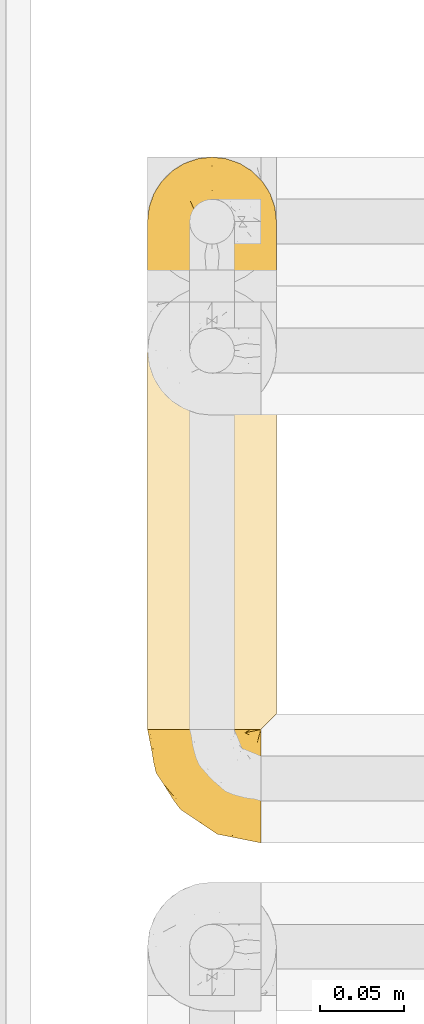
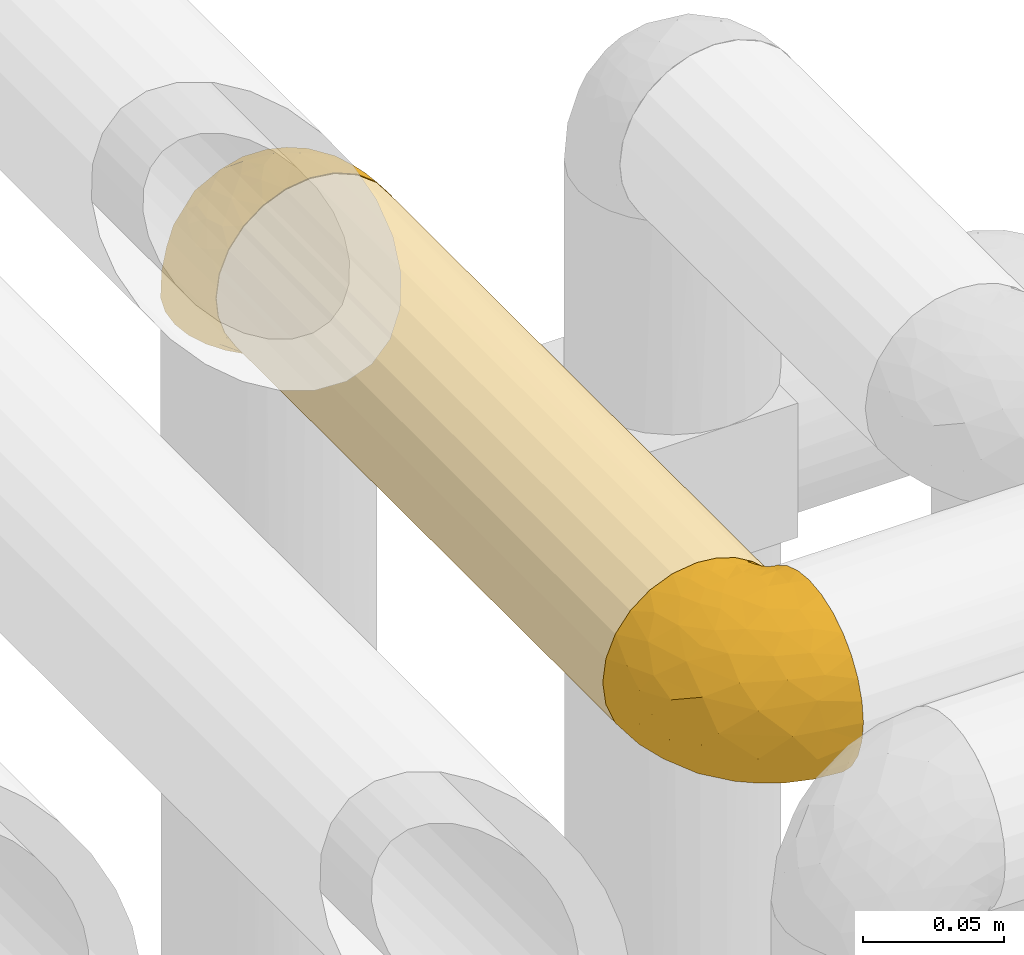
# One storey, part 286 of 827: 3 coverings.
"""IFC2X3 building model written with IfcOpenShell, lengths in millimetres."""

from ifc_helpers import new_model, entity, si_unit, converted_unit, derived_unit, direction, frame, origin, place, context, subcontext, project, spatial, faceted_brep, element, save


model = new_model("IFC2X3")

# Units and contexts
model_context = context("Model", 3, precision=0.01, world=origin(), true_north=direction((6.12303176911189e-17, 1.0)))
body_context = subcontext(model_context, "Body", "Model", "MODEL_VIEW")
ifc_project = project(units=[si_unit("LENGTHUNIT", "METRE", prefix="MILLI"), si_unit("AREAUNIT", "SQUARE_METRE"), si_unit("VOLUMEUNIT", "CUBIC_METRE"), converted_unit("PLANEANGLEUNIT", "DEGREE", entity("IfcRatioMeasure", 0.0174532925199433), si_unit("PLANEANGLEUNIT", "RADIAN"), dimensions=[0, 0, 0, 0, 0, 0, 0]), si_unit("MASSUNIT", "GRAM", prefix="KILO"), derived_unit("MASSDENSITYUNIT", [(si_unit("MASSUNIT", "GRAM", prefix="KILO"), 1), (si_unit("LENGTHUNIT", "METRE"), -3)]), derived_unit("MOMENTOFINERTIAUNIT", [(si_unit("LENGTHUNIT", "METRE"), 4)]), si_unit("TIMEUNIT", "SECOND"), si_unit("FREQUENCYUNIT", "HERTZ"), si_unit("THERMODYNAMICTEMPERATUREUNIT", "DEGREE_CELSIUS"), derived_unit("THERMALTRANSMITTANCEUNIT", [(si_unit("MASSUNIT", "GRAM", prefix="KILO"), 1), (si_unit("THERMODYNAMICTEMPERATUREUNIT", "KELVIN"), -1), (si_unit("TIMEUNIT", "SECOND"), -3)]), derived_unit("VOLUMETRICFLOWRATEUNIT", [(si_unit("LENGTHUNIT", "METRE"), 3), (si_unit("TIMEUNIT", "SECOND"), -1)]), derived_unit("MASSFLOWRATEUNIT", [(si_unit("MASSUNIT", "GRAM", prefix="KILO"), 1), (si_unit("TIMEUNIT", "SECOND"), -1)]), derived_unit("ROTATIONALFREQUENCYUNIT", [(si_unit("TIMEUNIT", "SECOND"), -1)]), si_unit("ELECTRICCURRENTUNIT", "AMPERE"), si_unit("ELECTRICVOLTAGEUNIT", "VOLT"), si_unit("POWERUNIT", "WATT"), si_unit("FORCEUNIT", "NEWTON", prefix="KILO"), si_unit("ILLUMINANCEUNIT", "LUX"), si_unit("LUMINOUSFLUXUNIT", "LUMEN"), si_unit("LUMINOUSINTENSITYUNIT", "CANDELA"), derived_unit("USERDEFINED", [(si_unit("MASSUNIT", "GRAM", prefix="KILO"), -1), (si_unit("LENGTHUNIT", "METRE"), -2), (si_unit("TIMEUNIT", "SECOND"), 3), (si_unit("LUMINOUSFLUXUNIT", "LUMEN"), 1)]), derived_unit("LINEARVELOCITYUNIT", [(si_unit("LENGTHUNIT", "METRE"), 1), (si_unit("TIMEUNIT", "SECOND"), -1)]), si_unit("PRESSUREUNIT", "PASCAL"), derived_unit("USERDEFINED", [(si_unit("LENGTHUNIT", "METRE"), -2), (si_unit("MASSUNIT", "GRAM", prefix="KILO"), 1), (si_unit("TIMEUNIT", "SECOND"), -2)]), derived_unit("LINEARFORCEUNIT", [(si_unit("MASSUNIT", "GRAM", prefix="KILO"), 1), (si_unit("LENGTHUNIT", "METRE"), 1), (si_unit("TIMEUNIT", "SECOND"), -2), (si_unit("LENGTHUNIT", "METRE"), -1)]), derived_unit("PLANARFORCEUNIT", [(si_unit("MASSUNIT", "GRAM", prefix="KILO"), 1), (si_unit("LENGTHUNIT", "METRE"), 1), (si_unit("TIMEUNIT", "SECOND"), -2), (si_unit("LENGTHUNIT", "METRE"), -2)])], contexts=[model_context])

# Site, building, storey
site_placement = place(None, origin())
site = spatial("IfcSite", under=ifc_project, at=site_placement, CompositionType="ELEMENT")
building_placement = place(site_placement, origin())
building = spatial("IfcBuilding", under=site, at=building_placement, CompositionType="ELEMENT")
storey_placement = place(building_placement, frame((0.0, 0.0, 28200.0)))
storey = spatial("IfcBuildingStorey", under=building, at=storey_placement, Name="08", CompositionType="ELEMENT", Elevation=28200.0)

# Coverings
covering_1_placement = place(storey_placement, frame((34787.85, 15517.5, 2960.0)))
element("IfcCovering", 1, at=covering_1_placement, inside=storey, Name=":ADSK_", ObjectType=":ADSK_", PredefinedType="INSULATION", context=body_context, shape_type="Brep", body=[
    faceted_brep([(20.8, 1.6, 6.74), (30.06, 1.6, 2.9), (40.0, 1.6, 1.6), (48.2, 1.6, 2.48), (56.01, 1.6, 5.09), (63.08, 1.6, 9.31), (69.1, 1.6, 14.94), (69.1, 1.6, 65.05), (63.08, 1.6, 70.68), (56.01, 1.6, 74.9), (48.2, 1.6, 77.51), (40.0, 1.6, 78.4), (30.06, 1.6, 77.09), (20.8, 1.6, 73.25), (12.84, 1.6, 67.15), (6.74, 1.6, 59.2), (2.9, 1.6, 49.93), (1.6, 1.6, 40.0), (2.9, 1.6, 30.06), (6.74, 1.6, 20.8), (12.84, 1.6, 12.84), (14.94, 275.44, 10.9), (9.31, 275.44, 16.91), (5.09, 275.44, 23.98), (2.48, 275.44, 31.79), (1.6, 275.44, 40.0), (2.9, 275.44, 49.93), (6.74, 275.44, 59.2), (12.84, 275.44, 67.15), (20.8, 275.44, 73.25), (30.06, 275.44, 77.09), (40.0, 275.44, 78.4), (49.93, 275.44, 77.09), (59.2, 275.44, 73.25), (67.15, 275.44, 67.15), (73.25, 275.44, 59.2), (77.09, 275.44, 49.93), (78.4, 275.44, 40.0), (77.51, 275.44, 31.79), (74.9, 275.44, 23.98), (70.68, 275.44, 16.91), (65.05, 275.44, 10.9), (20.48, 271.47, 6.92), (26.63, 268.54, 4.0), (33.21, 266.75, 2.2), (40.0, 266.14, 1.6), (46.78, 266.75, 2.2), (53.36, 268.54, 4.0), (59.51, 271.47, 6.92), (73.07, 5.57, 20.48), (76.0, 8.5, 26.63), (77.79, 10.29, 33.21), (78.4, 10.9, 40.0), (77.79, 10.29, 46.78), (76.0, 8.5, 53.36), (73.07, 5.57, 59.51)], [[[0, 1, 2, 3, 4, 5, 6, 7, 8, 9, 10, 11, 12, 13, 14, 15, 16, 17, 18, 19, 20]], [[21, 22, 23, 24, 25, 26, 27, 28, 29, 30, 31, 32, 33, 34, 35, 36, 37, 38, 39, 40, 41]], [[25, 24, 17]], [[24, 23, 18]], [[19, 23, 22]], [[18, 17, 24]], [[19, 18, 23]], [[22, 20, 19]], [[22, 21, 20]], [[21, 42, 0]], [[43, 44, 1]], [[42, 43, 0]], [[0, 43, 1]], [[2, 1, 44]], [[45, 2, 44]], [[21, 0, 20]], [[46, 47, 3]], [[48, 41, 5]], [[47, 48, 4]], [[45, 46, 2]], [[3, 2, 46]], [[47, 4, 3]], [[48, 5, 4]], [[41, 6, 5]], [[49, 40, 39]], [[50, 39, 38]], [[51, 38, 37]], [[49, 6, 40]], [[51, 50, 38]], [[52, 51, 37]], [[49, 39, 50]], [[40, 6, 41]], [[53, 52, 37]], [[53, 37, 36]], [[54, 36, 35]], [[54, 53, 36]], [[7, 55, 35]], [[54, 35, 55]], [[35, 34, 7]], [[8, 34, 33]], [[9, 33, 32]], [[10, 32, 31]], [[8, 33, 9]], [[9, 32, 10]], [[31, 11, 10]], [[34, 8, 7]], [[12, 11, 31, 30]], [[13, 12, 30, 29]], [[29, 28, 14, 13]], [[16, 15, 27, 26]], [[17, 16, 26, 25]], [[28, 27, 15, 14]], [[6, 49, 50, 51, 52, 53, 54, 55, 7]], [[48, 47, 46, 45, 44, 43, 42, 21, 41]]]),
])
covering_2_placement = place(storey_placement, frame((34787.8, 15449.95, 2959.95)))
element("IfcCovering", 2, at=covering_2_placement, inside=storey, Name=":ADSK_", ObjectType=":ADSK_", PredefinedType="INSULATION", context=body_context, shape_type="Brep", body=[
    faceted_brep([(69.15, 23.36, 74.68), (69.15, 16.07, 70.1), (69.15, 9.98, 64.01), (69.15, 5.4, 56.72), (69.15, 2.56, 48.6), (69.15, 1.6, 40.05), (69.15, 2.56, 31.49), (69.15, 5.41, 23.36), (69.15, 9.99, 16.07), (69.15, 16.08, 9.98), (69.15, 23.37, 5.4), (69.15, 31.49, 2.56), (69.15, 40.05, 1.6), (69.15, 48.15, 2.46), (69.15, 55.88, 5.01), (69.15, 62.9, 9.13), (69.15, 68.89, 14.62), (69.15, 68.89, 16.82), (69.15, 68.89, 18.56), (69.15, 68.89, 20.52), (69.15, 68.89, 22.49), (69.15, 68.89, 24.46), (69.15, 68.89, 26.42), (69.15, 68.89, 28.39), (69.15, 68.89, 30.36), (69.15, 68.89, 32.55), (69.15, 68.89, 34.75), (69.15, 68.89, 36.94), (69.15, 68.89, 39.13), (69.15, 68.89, 41.33), (69.15, 68.89, 43.52), (69.15, 68.89, 45.72), (69.15, 68.89, 47.91), (69.15, 68.89, 50.11), (69.15, 68.89, 52.3), (69.15, 68.89, 54.49), (69.15, 68.89, 56.69), (69.15, 68.89, 58.88), (69.15, 68.89, 61.08), (69.15, 68.89, 63.27), (69.15, 68.89, 65.47), (69.15, 62.89, 70.97), (69.15, 55.86, 75.09), (69.15, 48.13, 77.64), (69.15, 40.05, 78.5), (69.15, 31.49, 77.53), (68.89, 69.15, 14.62), (62.89, 69.15, 9.12), (55.87, 69.15, 5.0), (48.14, 69.15, 2.46), (40.05, 69.15, 1.6), (30.09, 69.15, 2.91), (20.82, 69.15, 6.75), (12.86, 69.15, 12.86), (6.75, 69.15, 20.82), (2.91, 69.15, 30.09), (1.6, 69.15, 40.05), (2.91, 69.15, 50.0), (6.75, 69.15, 59.27), (12.86, 69.15, 67.23), (20.82, 69.15, 73.34), (30.09, 69.15, 77.19), (40.05, 69.15, 78.5), (48.14, 69.15, 77.63), (55.87, 69.15, 75.09), (62.89, 69.15, 70.97), (68.89, 69.15, 65.47), (68.89, 69.15, 63.27), (68.89, 69.15, 62.29), (68.89, 69.15, 60.7), (68.89, 69.15, 59.11), (68.89, 69.15, 57.52), (68.89, 69.15, 55.93), (68.89, 69.15, 54.34), (68.89, 69.15, 52.76), (68.89, 69.15, 51.17), (68.89, 69.15, 49.58), (68.89, 69.15, 47.99), (68.89, 69.15, 46.4), (68.89, 69.15, 44.81), (68.89, 69.15, 43.22), (68.89, 69.15, 41.63), (68.89, 69.15, 40.05), (68.89, 69.15, 38.46), (68.89, 69.15, 36.87), (68.89, 69.15, 35.28), (68.89, 69.15, 33.69), (68.89, 69.15, 32.1), (68.89, 69.15, 30.51), (68.89, 69.15, 28.92), (68.89, 69.15, 27.33), (68.89, 69.15, 25.37), (68.89, 69.15, 23.4), (68.89, 69.15, 21.21), (68.89, 69.15, 19.01), (68.89, 69.15, 16.82), (68.97, 68.96, 42.32), (68.96, 68.97, 44.02), (68.97, 68.97, 47.13), (68.97, 68.97, 48.74), (68.98, 68.95, 23.57), (68.97, 68.96, 25.13), (68.96, 68.98, 61.34), (68.96, 68.97, 22.02), (68.96, 68.97, 29.72), (68.96, 68.98, 56.73), (68.96, 68.97, 55.14), (68.96, 68.97, 37.66), (69.0, 68.94, 64.12), (68.96, 68.98, 28.13), (68.96, 68.98, 26.62), (68.97, 68.96, 31.46), (68.96, 68.97, 16.16), (68.96, 68.98, 39.16), (68.96, 68.98, 50.37), (68.97, 68.97, 17.69), (68.97, 68.96, 19.17), (68.97, 68.97, 62.78), (68.96, 68.97, 58.35), (68.96, 68.98, 45.53), (68.97, 68.96, 59.91), (68.97, 68.97, 65.47), (69.02, 68.94, 65.47), (69.08, 68.92, 65.47), (68.97, 68.97, 14.62), (68.94, 69.02, 14.62), (68.92, 69.08, 14.62), (68.96, 68.98, 20.59), (68.96, 68.97, 32.99), (68.95, 68.98, 34.48), (68.96, 68.97, 51.91), (68.92, 69.08, 65.47), (68.94, 69.02, 65.47), (68.98, 68.96, 53.48), (69.08, 68.92, 14.62), (69.02, 68.94, 14.62), (68.96, 68.97, 40.77), (68.97, 68.96, 35.97), (61.33, 67.02, 7.84), (53.1, 63.33, 3.53), (63.33, 64.61, 8.32), (49.27, 49.27, 1.6), (55.53, 51.4, 2.19), (54.6, 43.94, 1.6), (41.99, 61.87, 1.6), (57.07, 61.54, 4.57), (57.95, 57.95, 3.96), (51.56, 56.12, 2.28), (41.58, 63.4, 1.6), (61.7, 65.41, 7.69), (63.33, 53.1, 3.53), (65.0, 63.04, 8.32), (67.02, 61.33, 7.84), (61.87, 41.99, 1.6), (43.94, 54.6, 1.6), (61.21, 56.6, 4.34), (63.4, 41.58, 1.6), (33.11, 13.72, 29.63), (52.82, 5.82, 27.34), (43.3, 6.74, 40.05), (33.73, 58.82, 2.39), (36.52, 51.58, 2.43), (24.87, 42.09, 9.07), (14.17, 46.12, 16.64), (18.43, 55.56, 9.54), (28.67, 52.38, 4.52), (26.0, 61.54, 4.52), (49.25, 23.76, 7.49), (59.72, 20.5, 7.49), (55.1, 14.64, 12.85), (44.72, 41.77, 2.35), (34.15, 16.28, 22.66), (5.25, 49.4, 32.9), (6.75, 52.34, 25.33), (55.54, 4.3, 40.05), (10.47, 58.67, 16.64), (25.49, 25.26, 19.99), (35.53, 20.17, 16.37), (48.22, 34.7, 3.26), (58.71, 28.67, 3.75), (57.42, 8.62, 19.58), (34.84, 33.37, 7.5), (36.87, 41.35, 4.04), (45.01, 17.15, 13.94), (44.4, 12.68, 19.58), (23.96, 21.47, 28.21), (11.2, 41.11, 24.75), (10.56, 37.53, 31.42), (16.81, 30.64, 26.2), (17.38, 26.66, 33.36), (21.38, 21.38, 40.05), (32.34, 14.06, 40.05), (4.3, 55.54, 40.05), (20.65, 35.17, 16.14), (29.66, 29.04, 12.85), (39.6, 24.34, 10.47), (42.55, 29.33, 6.49), (6.74, 43.3, 40.05), (14.06, 32.34, 40.05), (26.84, 57.75, 75.57), (5.28, 49.41, 47.37), (18.52, 27.85, 52.91), (33.13, 13.7, 50.46), (55.1, 14.63, 67.23), (57.43, 8.61, 60.5), (20.72, 48.85, 70.55), (11.46, 54.13, 63.45), (17.69, 37.84, 62.61), (49.26, 23.75, 72.6), (59.73, 20.49, 72.6), (58.71, 28.66, 76.34), (29.72, 20.83, 59.34), (35.35, 55.15, 77.76), (43.94, 54.6, 78.5), (41.99, 61.87, 78.5), (63.4, 41.58, 78.5), (4.93, 57.58, 53.16), (17.46, 59.91, 70.55), (10.94, 36.94, 48.88), (8.92, 45.72, 54.76), (52.83, 5.82, 52.74), (29.34, 37.91, 71.93), (30.26, 50.18, 75.79), (44.4, 12.67, 60.5), (39.06, 49.29, 77.86), (43.06, 42.64, 77.64), (54.6, 43.94, 78.5), (49.27, 49.27, 78.5), (42.69, 19.45, 67.23), (48.2, 34.7, 76.82), (61.87, 41.99, 78.5), (33.44, 62.29, 77.8), (29.67, 29.01, 67.23), (38.5, 31.47, 73.2), (23.35, 37.18, 67.66), (34.97, 43.45, 75.99), (53.1, 63.33, 76.57), (59.68, 67.23, 73.21), (62.19, 66.07, 71.93), (64.11, 65.22, 71.07), (57.97, 61.99, 75.09), (57.95, 57.95, 76.13), (63.33, 53.09, 76.57), (51.77, 56.84, 77.69), (67.02, 61.33, 72.26), (64.98, 63.06, 71.77), (55.53, 51.41, 77.9), (61.22, 56.61, 75.75)], [[[0, 1, 2, 3, 4, 5, 6, 7, 8, 9, 10, 11, 12, 13, 14, 15, 16, 17, 18, 19, 20, 21, 22, 23, 24, 25, 26, 27, 28, 29, 30, 31, 32, 33, 34, 35, 36, 37, 38, 39, 40, 41, 42, 43, 44, 45]], [[46, 47, 48, 49, 50, 51, 52, 53, 54, 55, 56, 57, 58, 59, 60, 61, 62, 63, 64, 65, 66, 67, 68, 69, 70, 71, 72, 73, 74, 75, 76, 77, 78, 79, 80, 81, 82, 83, 84, 85, 86, 87, 88, 89, 90, 91, 92, 93, 94, 95]], [[96, 97, 30]], [[98, 77, 99]], [[100, 101, 21]], [[69, 68, 102]], [[20, 19, 103]], [[24, 23, 104]], [[20, 103, 100]], [[72, 105, 106]], [[84, 83, 107]], [[89, 88, 104]], [[108, 67, 66]], [[109, 110, 90]], [[111, 25, 24]], [[112, 17, 16]], [[82, 113, 83]], [[109, 23, 22]], [[114, 76, 75]], [[105, 36, 106]], [[104, 111, 24]], [[18, 115, 116]], [[97, 96, 80]], [[67, 108, 117]], [[105, 71, 118]], [[31, 97, 119]], [[102, 120, 69]], [[108, 121, 122, 123, 40]], [[112, 95, 115]], [[17, 115, 18]], [[94, 116, 115]], [[117, 68, 67]], [[38, 117, 39]], [[112, 124, 125, 126, 46]], [[17, 112, 115]], [[70, 120, 118]], [[39, 117, 108]], [[120, 38, 37]], [[120, 37, 118]], [[120, 70, 69]], [[116, 94, 127]], [[128, 86, 129]], [[117, 38, 102]], [[74, 130, 75]], [[99, 33, 32]], [[115, 95, 94]], [[39, 108, 40]], [[108, 66, 131, 132, 121]], [[105, 72, 71]], [[118, 37, 36]], [[71, 70, 118]], [[35, 106, 36]], [[36, 105, 118]], [[35, 133, 106]], [[74, 73, 133]], [[106, 133, 73]], [[99, 114, 33]], [[133, 35, 34]], [[73, 72, 106]], [[95, 112, 46]], [[112, 16, 134, 135, 124]], [[130, 114, 75]], [[99, 76, 114]], [[114, 130, 33]], [[34, 33, 130]], [[78, 77, 98]], [[98, 119, 78]], [[130, 133, 34]], [[133, 130, 74]], [[79, 97, 80]], [[98, 99, 32]], [[98, 32, 31]], [[77, 76, 99]], [[97, 79, 119]], [[136, 96, 29]], [[30, 97, 31]], [[136, 29, 28]], [[81, 80, 96]], [[29, 96, 30]], [[31, 119, 98]], [[119, 79, 78]], [[96, 136, 81]], [[82, 81, 136]], [[113, 107, 83]], [[84, 107, 137]], [[107, 27, 137]], [[113, 28, 107]], [[27, 107, 28]], [[85, 84, 137]], [[137, 27, 26]], [[113, 136, 28]], [[136, 113, 82]], [[109, 89, 104]], [[86, 85, 129]], [[89, 109, 90]], [[111, 87, 128]], [[26, 129, 137]], [[88, 111, 104]], [[25, 111, 128]], [[22, 110, 109]], [[23, 109, 104]], [[110, 91, 90]], [[100, 92, 101]], [[110, 22, 101]], [[91, 110, 101]], [[116, 19, 18]], [[111, 88, 87]], [[127, 103, 19]], [[25, 128, 26]], [[86, 128, 87]], [[128, 129, 26]], [[137, 129, 85]], [[120, 102, 38]], [[117, 102, 68]], [[91, 101, 92]], [[21, 101, 22]], [[93, 92, 103]], [[100, 21, 20]], [[100, 103, 92]], [[127, 93, 103]], [[93, 127, 94]], [[116, 127, 19]], [[126, 138, 47]], [[48, 138, 139]], [[140, 125, 124]], [[141, 142, 143]], [[144, 49, 139]], [[145, 140, 146]], [[48, 139, 49]], [[139, 145, 147]], [[49, 144, 148, 50]], [[126, 125, 149]], [[14, 13, 150]], [[151, 146, 140]], [[149, 140, 145]], [[152, 151, 135]], [[152, 14, 150]], [[16, 15, 134]], [[13, 153, 150]], [[124, 151, 140]], [[141, 147, 142]], [[14, 152, 15]], [[15, 152, 134]], [[47, 46, 126]], [[139, 154, 144]], [[138, 48, 47]], [[125, 140, 149]], [[135, 134, 152]], [[146, 155, 142]], [[145, 146, 147]], [[149, 139, 138]], [[147, 141, 154]], [[147, 146, 142]], [[139, 147, 154]], [[139, 149, 145]], [[149, 138, 126]], [[155, 146, 151]], [[150, 143, 142]], [[152, 155, 151]], [[150, 142, 155]], [[13, 12, 156, 153]], [[153, 143, 150]], [[152, 150, 155]], [[151, 124, 135]], [[157, 158, 159]], [[160, 154, 161]], [[162, 163, 164]], [[165, 166, 160]], [[167, 168, 169]], [[141, 170, 161]], [[156, 12, 11]], [[158, 157, 171]], [[172, 55, 173]], [[158, 6, 174]], [[175, 54, 53]], [[52, 166, 164]], [[52, 164, 53]], [[54, 175, 173]], [[166, 52, 51]], [[176, 177, 171]], [[178, 143, 179]], [[156, 11, 179]], [[8, 7, 180]], [[169, 9, 8]], [[179, 143, 153, 156]], [[179, 11, 10]], [[168, 179, 10]], [[181, 162, 182]], [[179, 167, 178]], [[183, 184, 177]], [[183, 169, 184]], [[176, 171, 185]], [[172, 186, 187]], [[158, 7, 6]], [[159, 158, 174]], [[184, 180, 158]], [[54, 173, 55]], [[180, 169, 8]], [[188, 189, 187]], [[9, 168, 10]], [[186, 188, 187]], [[190, 157, 159, 191]], [[55, 172, 192]], [[176, 193, 194]], [[161, 170, 182]], [[162, 164, 165]], [[175, 164, 163]], [[51, 50, 148]], [[167, 195, 196]], [[178, 182, 170]], [[6, 5, 174]], [[158, 180, 7]], [[169, 180, 184]], [[169, 168, 9]], [[179, 168, 167]], [[182, 162, 165]], [[162, 194, 193]], [[161, 165, 160]], [[195, 181, 196]], [[192, 172, 197]], [[192, 56, 55]], [[189, 190, 198]], [[198, 197, 187]], [[172, 187, 197]], [[185, 189, 188]], [[198, 187, 189]], [[186, 172, 173]], [[173, 163, 186]], [[193, 186, 163]], [[176, 185, 188]], [[185, 157, 190]], [[188, 186, 193]], [[177, 176, 194]], [[188, 193, 176]], [[162, 193, 163]], [[195, 177, 194]], [[171, 177, 184]], [[181, 195, 194]], [[183, 167, 169]], [[162, 181, 194]], [[196, 182, 178]], [[158, 171, 184]], [[171, 157, 185]], [[177, 195, 183]], [[167, 183, 195]], [[182, 196, 181]], [[178, 170, 143]], [[178, 167, 196]], [[164, 175, 53]], [[173, 175, 163]], [[160, 51, 148]], [[164, 166, 165]], [[51, 160, 166]], [[160, 148, 144, 154]], [[141, 161, 154]], [[182, 165, 161]], [[190, 189, 185]], [[143, 170, 141]], [[60, 199, 61]], [[197, 200, 192]], [[201, 190, 202]], [[200, 57, 192]], [[203, 204, 2]], [[205, 206, 207]], [[208, 209, 210]], [[211, 207, 201]], [[212, 213, 214]], [[45, 215, 210]], [[216, 206, 58]], [[45, 44, 215]], [[59, 217, 60]], [[60, 217, 199]], [[0, 45, 210]], [[218, 201, 219]], [[202, 159, 220]], [[205, 221, 222]], [[223, 204, 203]], [[1, 203, 2]], [[57, 200, 216]], [[220, 3, 204]], [[220, 174, 4]], [[1, 0, 209]], [[212, 224, 213]], [[225, 226, 227]], [[228, 223, 203]], [[208, 210, 229]], [[210, 226, 229]], [[3, 220, 4]], [[58, 206, 59]], [[209, 203, 1]], [[202, 220, 223]], [[228, 203, 208]], [[202, 211, 201]], [[3, 2, 204]], [[202, 190, 191, 159]], [[210, 215, 230, 226]], [[199, 212, 231]], [[232, 233, 221]], [[233, 208, 229]], [[207, 206, 219]], [[217, 206, 205]], [[227, 224, 225]], [[233, 232, 228]], [[201, 207, 219]], [[234, 232, 221]], [[218, 219, 200]], [[202, 223, 211]], [[174, 220, 159]], [[174, 5, 4]], [[61, 231, 62]], [[220, 204, 223]], [[210, 209, 0]], [[203, 209, 208]], [[225, 233, 229]], [[224, 227, 213]], [[221, 233, 235]], [[57, 56, 192]], [[198, 218, 197]], [[200, 219, 216]], [[201, 198, 190]], [[197, 218, 200]], [[198, 201, 218]], [[206, 216, 219]], [[58, 57, 216]], [[231, 212, 214]], [[222, 212, 199]], [[228, 211, 223]], [[207, 211, 232]], [[62, 231, 214]], [[199, 231, 61]], [[233, 228, 208]], [[211, 228, 232]], [[222, 221, 235]], [[234, 205, 207]], [[206, 217, 59]], [[199, 217, 205]], [[205, 222, 199]], [[224, 222, 235]], [[222, 224, 212]], [[224, 235, 225]], [[233, 225, 235]], [[226, 225, 229]], [[205, 234, 221]], [[207, 232, 234]], [[63, 214, 236]], [[214, 213, 236]], [[214, 63, 62]], [[237, 236, 238]], [[238, 132, 131]], [[236, 237, 64]], [[239, 240, 241]], [[63, 236, 64]], [[131, 66, 65]], [[237, 131, 65]], [[242, 230, 43]], [[237, 65, 64]], [[239, 121, 132]], [[42, 242, 43]], [[241, 240, 243]], [[41, 123, 244]], [[43, 230, 215, 44]], [[244, 122, 245]], [[227, 246, 243]], [[241, 247, 245]], [[121, 239, 245]], [[41, 40, 123]], [[132, 238, 239]], [[244, 42, 41]], [[131, 237, 238]], [[240, 239, 238]], [[245, 239, 241]], [[247, 241, 246]], [[247, 244, 245]], [[238, 236, 240]], [[243, 236, 213]], [[236, 243, 240]], [[227, 226, 246]], [[243, 213, 227]], [[242, 246, 226]], [[243, 246, 241]], [[246, 242, 247]], [[244, 247, 242]], [[242, 226, 230]], [[42, 244, 242]], [[122, 244, 123]], [[122, 121, 245]]]),
])
covering_3_placement = place(storey_placement, frame((34787.8, 15791.35, 2969.5)))
element("IfcCovering", 3, at=covering_3_placement, inside=storey, Name=":ADSK_", ObjectType=":ADSK_", PredefinedType="INSULATION", context=body_context, shape_type="Brep", body=[
    faceted_brep([(5.41, 47.38, 1.6), (9.99, 54.67, 1.6), (16.08, 60.76, 1.6), (23.37, 65.34, 1.6), (31.49, 68.18, 1.6), (40.05, 69.15, 1.6), (48.61, 68.18, 1.6), (56.73, 65.33, 1.6), (64.02, 60.75, 1.6), (70.11, 54.66, 1.6), (74.69, 47.37, 1.6), (77.53, 39.25, 1.6), (78.5, 30.7, 1.6), (77.63, 22.59, 1.6), (75.08, 14.86, 1.6), (70.97, 7.84, 1.6), (65.47, 1.85, 1.6), (63.27, 1.85, 1.6), (61.53, 1.85, 1.6), (59.57, 1.85, 1.6), (57.6, 1.85, 1.6), (55.63, 1.85, 1.6), (53.67, 1.85, 1.6), (51.7, 1.85, 1.6), (49.73, 1.85, 1.6), (47.54, 1.85, 1.6), (45.34, 1.85, 1.6), (43.15, 1.85, 1.6), (40.96, 1.85, 1.6), (38.76, 1.85, 1.6), (36.57, 1.85, 1.6), (34.37, 1.85, 1.6), (32.18, 1.85, 1.6), (29.98, 1.85, 1.6), (27.79, 1.85, 1.6), (25.6, 1.85, 1.6), (23.4, 1.85, 1.6), (21.21, 1.85, 1.6), (19.01, 1.85, 1.6), (16.82, 1.85, 1.6), (14.62, 1.85, 1.6), (9.12, 7.85, 1.6), (5.0, 14.88, 1.6), (2.46, 22.61, 1.6), (1.6, 30.7, 1.6), (2.56, 39.26, 1.6), (65.47, 1.6, 1.85), (70.97, 1.6, 7.85), (75.09, 1.6, 14.87), (77.63, 1.6, 22.6), (78.5, 1.6, 30.7), (77.19, 1.6, 40.65), (73.34, 1.6, 49.92), (67.23, 1.6, 57.88), (59.27, 1.6, 63.99), (50.0, 1.6, 67.84), (40.05, 1.6, 69.15), (30.09, 1.6, 67.84), (20.82, 1.6, 63.99), (12.86, 1.6, 57.88), (6.75, 1.6, 49.92), (2.91, 1.6, 40.65), (1.6, 1.6, 30.7), (2.46, 1.6, 22.6), (5.0, 1.6, 14.87), (9.12, 1.6, 7.85), (14.62, 1.6, 1.85), (16.82, 1.6, 1.85), (17.8, 1.6, 1.85), (19.39, 1.6, 1.85), (20.98, 1.6, 1.85), (22.57, 1.6, 1.85), (24.16, 1.6, 1.85), (25.75, 1.6, 1.85), (27.33, 1.6, 1.85), (28.92, 1.6, 1.85), (30.51, 1.6, 1.85), (32.1, 1.6, 1.85), (33.69, 1.6, 1.85), (35.28, 1.6, 1.85), (36.87, 1.6, 1.85), (38.46, 1.6, 1.85), (40.05, 1.6, 1.85), (41.63, 1.6, 1.85), (43.22, 1.6, 1.85), (44.81, 1.6, 1.85), (46.4, 1.6, 1.85), (47.99, 1.6, 1.85), (49.58, 1.6, 1.85), (51.17, 1.6, 1.85), (52.76, 1.6, 1.85), (54.72, 1.6, 1.85), (56.69, 1.6, 1.85), (58.88, 1.6, 1.85), (61.08, 1.6, 1.85), (63.27, 1.6, 1.85), (37.77, 1.78, 1.77), (36.07, 1.77, 1.78), (32.96, 1.78, 1.77), (31.36, 1.77, 1.77), (56.52, 1.79, 1.76), (54.96, 1.78, 1.77), (18.75, 1.76, 1.79), (58.07, 1.77, 1.78), (50.37, 1.77, 1.78), (23.36, 1.76, 1.78), (24.95, 1.77, 1.78), (42.43, 1.77, 1.78), (15.97, 1.8, 1.74), (51.96, 1.76, 1.78), (53.47, 1.77, 1.78), (48.63, 1.78, 1.77), (63.93, 1.77, 1.78), (40.93, 1.77, 1.78), (29.72, 1.76, 1.78), (62.4, 1.77, 1.77), (60.92, 1.78, 1.77), (17.31, 1.77, 1.77), (21.74, 1.77, 1.78), (34.56, 1.77, 1.78), (20.18, 1.78, 1.77), (14.62, 1.77, 1.77), (14.62, 1.8, 1.72), (14.62, 1.82, 1.66), (65.47, 1.77, 1.77), (65.47, 1.72, 1.8), (65.47, 1.66, 1.82), (59.5, 1.76, 1.79), (47.1, 1.77, 1.78), (45.61, 1.76, 1.79), (28.18, 1.77, 1.78), (14.62, 1.66, 1.82), (14.62, 1.72, 1.8), (26.61, 1.78, 1.76), (65.47, 1.82, 1.66), (65.47, 1.8, 1.72), (39.32, 1.77, 1.78), (44.12, 1.78, 1.77), (72.26, 3.72, 9.41), (76.57, 7.41, 17.65), (71.77, 6.13, 7.41), (78.5, 21.47, 21.47), (77.9, 19.34, 15.21), (78.5, 26.8, 16.15), (78.5, 8.87, 28.75), (75.52, 9.2, 13.67), (76.13, 12.79, 12.79), (77.81, 14.62, 19.18), (78.5, 7.34, 29.16), (72.4, 5.33, 9.04), (76.56, 17.64, 7.41), (71.77, 7.7, 5.74), (72.25, 9.41, 3.72), (78.5, 28.75, 8.87), (78.5, 16.15, 26.8), (75.75, 14.14, 9.53), (78.5, 29.16, 7.34), (50.46, 57.02, 37.63), (52.75, 64.92, 17.92), (40.05, 64.0, 27.45), (77.7, 11.92, 37.01), (77.66, 19.16, 34.22), (71.02, 28.65, 45.87), (63.45, 24.62, 56.57), (70.55, 15.19, 52.31), (75.57, 18.36, 42.07), (75.57, 9.2, 44.74), (72.61, 46.98, 21.49), (72.61, 50.24, 11.02), (67.24, 56.1, 15.64), (77.74, 28.97, 26.02), (57.43, 54.46, 36.59), (47.19, 21.34, 65.49), (54.76, 18.4, 63.99), (40.05, 66.44, 15.2), (63.45, 12.07, 60.27), (60.1, 45.49, 45.25), (63.72, 50.57, 35.21), (76.83, 36.04, 22.52), (76.34, 42.07, 12.03), (60.51, 62.12, 13.32), (72.59, 37.37, 35.9), (76.05, 29.39, 33.87), (66.15, 53.59, 25.73), (60.51, 58.06, 26.34), (51.88, 49.27, 46.78), (55.34, 29.63, 59.54), (48.67, 33.21, 60.18), (53.89, 40.1, 53.93), (46.73, 44.08, 53.36), (40.05, 49.36, 49.36), (40.05, 56.68, 38.4), (40.05, 15.2, 66.44), (63.95, 35.57, 50.09), (67.24, 41.7, 41.08), (69.62, 46.4, 31.14), (73.6, 41.41, 28.19), (40.05, 27.45, 64.0), (40.05, 38.4, 56.68), (4.52, 12.99, 43.9), (32.72, 21.33, 65.46), (27.18, 42.89, 52.22), (29.63, 57.04, 37.61), (12.86, 56.11, 15.64), (19.59, 62.13, 13.31), (9.54, 21.89, 50.02), (16.64, 16.62, 59.28), (17.48, 32.9, 53.05), (7.49, 46.99, 21.48), (7.49, 50.25, 11.01), (3.75, 42.08, 12.03), (20.75, 49.91, 41.02), (2.33, 15.6, 35.39), (1.6, 16.15, 26.8), (1.6, 8.87, 28.75), (1.6, 29.16, 7.34), (26.94, 13.16, 65.81), (9.54, 10.83, 53.28), (31.21, 33.8, 59.8), (25.33, 25.02, 61.82), (27.35, 64.92, 17.91), (8.17, 32.83, 41.4), (4.3, 20.56, 40.48), (19.59, 58.07, 26.34), (2.23, 21.46, 31.68), (2.45, 28.1, 27.68), (1.6, 26.8, 16.15), (1.6, 21.47, 21.47), (12.86, 51.29, 28.05), (3.27, 36.04, 22.54), (1.6, 28.75, 8.87), (2.29, 8.45, 37.3), (12.86, 41.73, 41.07), (6.89, 39.27, 32.24), (12.43, 33.56, 47.4), (4.1, 27.29, 35.77), (3.53, 7.41, 17.65), (6.88, 3.51, 11.06), (8.16, 4.68, 8.55), (9.02, 5.52, 6.63), (5.0, 8.75, 12.77), (3.96, 12.79, 12.79), (3.52, 17.65, 7.41), (2.4, 13.9, 18.97), (7.83, 9.42, 3.72), (8.32, 7.68, 5.76), (2.19, 19.33, 15.21), (4.34, 14.13, 9.52)], [[[0, 1, 2, 3, 4, 5, 6, 7, 8, 9, 10, 11, 12, 13, 14, 15, 16, 17, 18, 19, 20, 21, 22, 23, 24, 25, 26, 27, 28, 29, 30, 31, 32, 33, 34, 35, 36, 37, 38, 39, 40, 41, 42, 43, 44, 45]], [[46, 47, 48, 49, 50, 51, 52, 53, 54, 55, 56, 57, 58, 59, 60, 61, 62, 63, 64, 65, 66, 67, 68, 69, 70, 71, 72, 73, 74, 75, 76, 77, 78, 79, 80, 81, 82, 83, 84, 85, 86, 87, 88, 89, 90, 91, 92, 93, 94, 95]], [[96, 97, 30]], [[98, 77, 99]], [[100, 101, 21]], [[69, 68, 102]], [[20, 19, 103]], [[24, 23, 104]], [[20, 103, 100]], [[72, 105, 106]], [[84, 83, 107]], [[89, 88, 104]], [[108, 67, 66]], [[109, 110, 90]], [[111, 25, 24]], [[112, 17, 16]], [[82, 113, 83]], [[109, 23, 22]], [[114, 76, 75]], [[105, 36, 106]], [[104, 111, 24]], [[18, 115, 116]], [[97, 96, 80]], [[67, 108, 117]], [[105, 71, 118]], [[31, 97, 119]], [[102, 120, 69]], [[108, 121, 122, 123, 40]], [[112, 95, 115]], [[17, 115, 18]], [[94, 116, 115]], [[117, 68, 67]], [[38, 117, 39]], [[112, 124, 125, 126, 46]], [[17, 112, 115]], [[70, 120, 118]], [[39, 117, 108]], [[120, 38, 37]], [[120, 37, 118]], [[120, 70, 69]], [[116, 94, 127]], [[128, 86, 129]], [[117, 38, 102]], [[74, 130, 75]], [[99, 33, 32]], [[115, 95, 94]], [[39, 108, 40]], [[108, 66, 131, 132, 121]], [[105, 72, 71]], [[118, 37, 36]], [[71, 70, 118]], [[35, 106, 36]], [[36, 105, 118]], [[35, 133, 106]], [[74, 73, 133]], [[106, 133, 73]], [[99, 114, 33]], [[133, 35, 34]], [[73, 72, 106]], [[95, 112, 46]], [[112, 16, 134, 135, 124]], [[130, 114, 75]], [[99, 76, 114]], [[114, 130, 33]], [[34, 33, 130]], [[78, 77, 98]], [[98, 119, 78]], [[130, 133, 34]], [[133, 130, 74]], [[79, 97, 80]], [[98, 99, 32]], [[98, 32, 31]], [[77, 76, 99]], [[97, 79, 119]], [[136, 96, 29]], [[30, 97, 31]], [[136, 29, 28]], [[81, 80, 96]], [[29, 96, 30]], [[31, 119, 98]], [[119, 79, 78]], [[96, 136, 81]], [[82, 81, 136]], [[113, 107, 83]], [[84, 107, 137]], [[107, 27, 137]], [[113, 28, 107]], [[27, 107, 28]], [[85, 84, 137]], [[137, 27, 26]], [[113, 136, 28]], [[136, 113, 82]], [[109, 89, 104]], [[86, 85, 129]], [[89, 109, 90]], [[111, 87, 128]], [[26, 129, 137]], [[88, 111, 104]], [[25, 111, 128]], [[22, 110, 109]], [[23, 109, 104]], [[110, 91, 90]], [[100, 92, 101]], [[110, 22, 101]], [[91, 110, 101]], [[116, 19, 18]], [[111, 88, 87]], [[127, 103, 19]], [[25, 128, 26]], [[86, 128, 87]], [[128, 129, 26]], [[137, 129, 85]], [[120, 102, 38]], [[117, 102, 68]], [[91, 101, 92]], [[21, 101, 22]], [[93, 92, 103]], [[100, 21, 20]], [[100, 103, 92]], [[127, 93, 103]], [[93, 127, 94]], [[116, 127, 19]], [[126, 138, 47]], [[48, 138, 139]], [[140, 125, 124]], [[141, 142, 143]], [[144, 49, 139]], [[145, 140, 146]], [[48, 139, 49]], [[139, 145, 147]], [[49, 144, 148, 50]], [[126, 125, 149]], [[14, 13, 150]], [[151, 146, 140]], [[149, 140, 145]], [[152, 151, 135]], [[152, 14, 150]], [[16, 15, 134]], [[13, 153, 150]], [[124, 151, 140]], [[141, 147, 142]], [[14, 152, 15]], [[15, 152, 134]], [[47, 46, 126]], [[139, 154, 144]], [[138, 48, 47]], [[125, 140, 149]], [[135, 134, 152]], [[146, 155, 142]], [[145, 146, 147]], [[149, 139, 138]], [[147, 141, 154]], [[147, 146, 142]], [[139, 147, 154]], [[139, 149, 145]], [[149, 138, 126]], [[155, 146, 151]], [[150, 143, 142]], [[152, 155, 151]], [[150, 142, 155]], [[13, 12, 156, 153]], [[153, 143, 150]], [[152, 150, 155]], [[151, 124, 135]], [[157, 158, 159]], [[160, 154, 161]], [[162, 163, 164]], [[165, 166, 160]], [[167, 168, 169]], [[141, 170, 161]], [[156, 12, 11]], [[158, 157, 171]], [[172, 55, 173]], [[158, 6, 174]], [[175, 54, 53]], [[52, 166, 164]], [[52, 164, 53]], [[54, 175, 173]], [[166, 52, 51]], [[176, 177, 171]], [[178, 143, 179]], [[156, 11, 179]], [[8, 7, 180]], [[169, 9, 8]], [[179, 143, 153, 156]], [[179, 11, 10]], [[168, 179, 10]], [[181, 162, 182]], [[179, 167, 178]], [[183, 184, 177]], [[183, 169, 184]], [[176, 171, 185]], [[172, 186, 187]], [[158, 7, 6]], [[159, 158, 174]], [[184, 180, 158]], [[54, 173, 55]], [[180, 169, 8]], [[188, 189, 187]], [[9, 168, 10]], [[186, 188, 187]], [[190, 157, 159, 191]], [[55, 172, 192]], [[176, 193, 194]], [[161, 170, 182]], [[162, 164, 165]], [[175, 164, 163]], [[51, 50, 148]], [[167, 195, 196]], [[178, 182, 170]], [[6, 5, 174]], [[158, 180, 7]], [[169, 180, 184]], [[169, 168, 9]], [[179, 168, 167]], [[182, 162, 165]], [[162, 194, 193]], [[161, 165, 160]], [[195, 181, 196]], [[192, 172, 197]], [[192, 56, 55]], [[189, 190, 198]], [[198, 197, 187]], [[172, 187, 197]], [[185, 189, 188]], [[198, 187, 189]], [[186, 172, 173]], [[173, 163, 186]], [[193, 186, 163]], [[176, 185, 188]], [[185, 157, 190]], [[188, 186, 193]], [[177, 176, 194]], [[188, 193, 176]], [[162, 193, 163]], [[195, 177, 194]], [[171, 177, 184]], [[181, 195, 194]], [[183, 167, 169]], [[162, 181, 194]], [[196, 182, 178]], [[158, 171, 184]], [[171, 157, 185]], [[177, 195, 183]], [[167, 183, 195]], [[182, 196, 181]], [[178, 170, 143]], [[178, 167, 196]], [[164, 175, 53]], [[173, 175, 163]], [[160, 51, 148]], [[164, 166, 165]], [[51, 160, 166]], [[160, 148, 144, 154]], [[141, 161, 154]], [[182, 165, 161]], [[190, 189, 185]], [[143, 170, 141]], [[60, 199, 61]], [[197, 200, 192]], [[201, 190, 202]], [[200, 57, 192]], [[203, 204, 2]], [[205, 206, 207]], [[208, 209, 210]], [[211, 207, 201]], [[212, 213, 214]], [[45, 215, 210]], [[216, 206, 58]], [[45, 44, 215]], [[59, 217, 60]], [[60, 217, 199]], [[0, 45, 210]], [[218, 201, 219]], [[202, 159, 220]], [[205, 221, 222]], [[223, 204, 203]], [[1, 203, 2]], [[57, 200, 216]], [[220, 3, 204]], [[220, 174, 4]], [[1, 0, 209]], [[212, 224, 213]], [[225, 226, 227]], [[228, 223, 203]], [[208, 210, 229]], [[210, 226, 229]], [[3, 220, 4]], [[58, 206, 59]], [[209, 203, 1]], [[202, 220, 223]], [[228, 203, 208]], [[202, 211, 201]], [[3, 2, 204]], [[202, 190, 191, 159]], [[210, 215, 230, 226]], [[199, 212, 231]], [[232, 233, 221]], [[233, 208, 229]], [[207, 206, 219]], [[217, 206, 205]], [[227, 224, 225]], [[233, 232, 228]], [[201, 207, 219]], [[234, 232, 221]], [[218, 219, 200]], [[202, 223, 211]], [[174, 220, 159]], [[174, 5, 4]], [[61, 231, 62]], [[220, 204, 223]], [[210, 209, 0]], [[203, 209, 208]], [[225, 233, 229]], [[224, 227, 213]], [[221, 233, 235]], [[57, 56, 192]], [[198, 218, 197]], [[200, 219, 216]], [[201, 198, 190]], [[197, 218, 200]], [[198, 201, 218]], [[206, 216, 219]], [[58, 57, 216]], [[231, 212, 214]], [[222, 212, 199]], [[228, 211, 223]], [[207, 211, 232]], [[62, 231, 214]], [[199, 231, 61]], [[233, 228, 208]], [[211, 228, 232]], [[222, 221, 235]], [[234, 205, 207]], [[206, 217, 59]], [[199, 217, 205]], [[205, 222, 199]], [[224, 222, 235]], [[222, 224, 212]], [[224, 235, 225]], [[233, 225, 235]], [[226, 225, 229]], [[205, 234, 221]], [[207, 232, 234]], [[63, 214, 236]], [[214, 213, 236]], [[214, 63, 62]], [[237, 236, 238]], [[238, 132, 131]], [[236, 237, 64]], [[239, 240, 241]], [[63, 236, 64]], [[131, 66, 65]], [[237, 131, 65]], [[242, 230, 43]], [[237, 65, 64]], [[239, 121, 132]], [[42, 242, 43]], [[241, 240, 243]], [[41, 123, 244]], [[43, 230, 215, 44]], [[244, 122, 245]], [[227, 246, 243]], [[241, 247, 245]], [[121, 239, 245]], [[41, 40, 123]], [[132, 238, 239]], [[244, 42, 41]], [[131, 237, 238]], [[240, 239, 238]], [[245, 239, 241]], [[247, 241, 246]], [[247, 244, 245]], [[238, 236, 240]], [[243, 236, 213]], [[236, 243, 240]], [[227, 226, 246]], [[243, 213, 227]], [[242, 246, 226]], [[243, 246, 241]], [[246, 242, 247]], [[244, 247, 242]], [[242, 226, 230]], [[42, 244, 242]], [[122, 244, 123]], [[122, 121, 245]]]),
])

save(model, "model.ifc")
